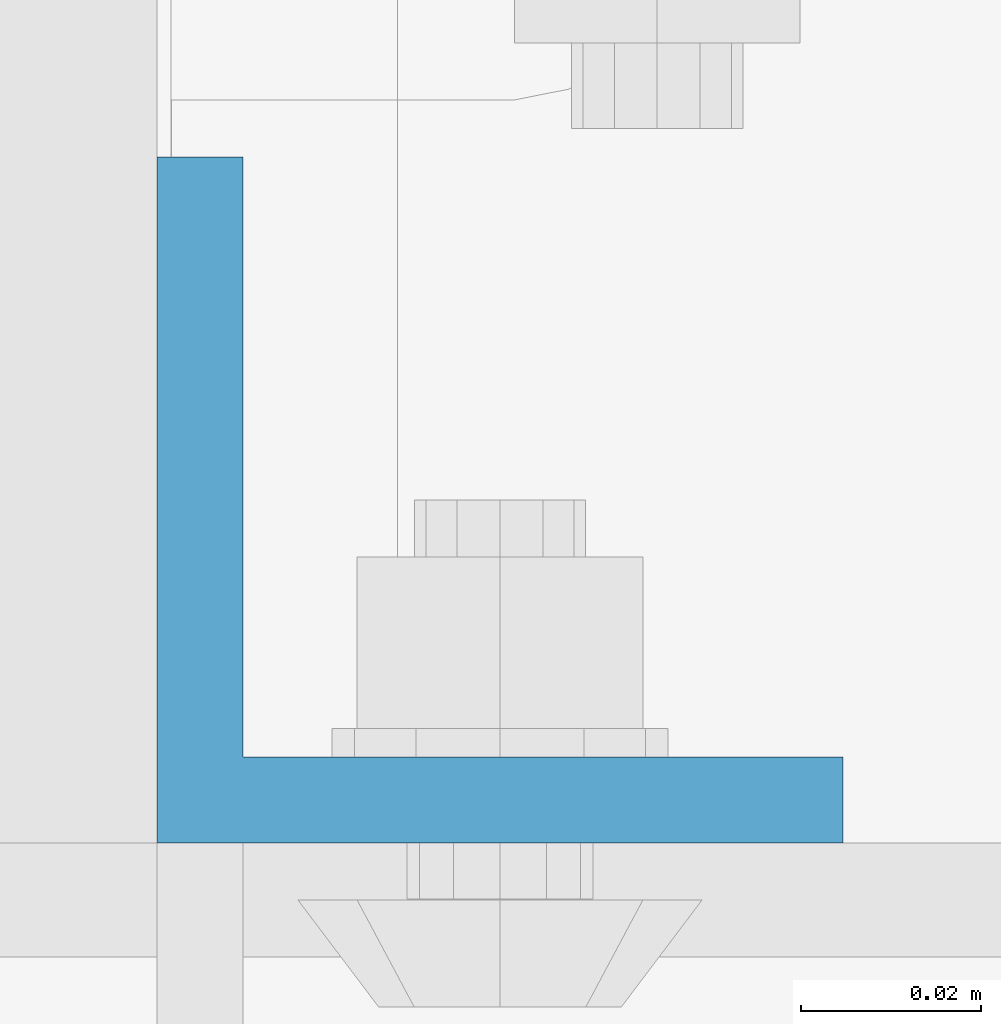
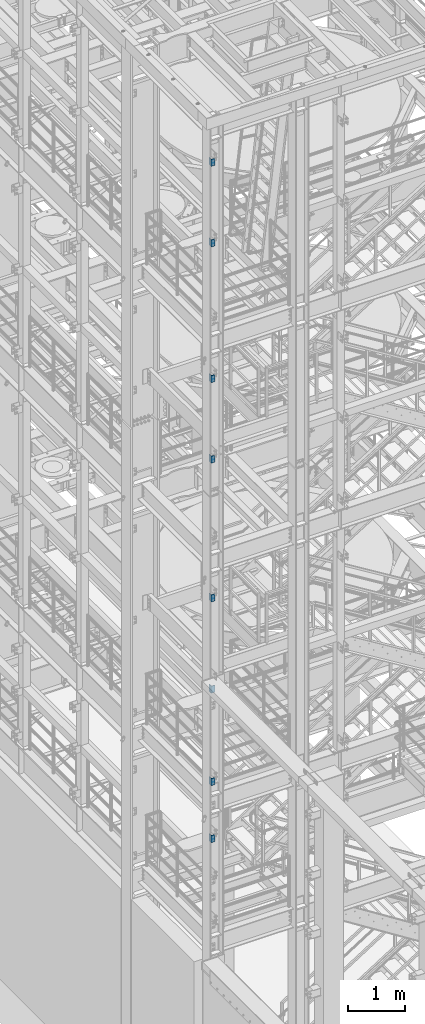
# One storey, part 800 of 1876: 8 columns, 2 elements without a shape of their own.
"""IFC2X3 building model written with IfcOpenShell, lengths in millimetres."""

from ifc_helpers import new_model, si_unit, frame, origin_with_axes, place, context, subcontext, project, spatial, faceted_brep, material, type_object, element, aggregate, save


model = new_model("IFC2X3")

# Units and contexts
model_context = context("Model", 3, precision=1e-05, world=origin_with_axes())
body_context = subcontext(model_context, "Body", "Model", "MODEL_VIEW")
ifc_project = project(units=[si_unit("LENGTHUNIT", "METRE", prefix="MILLI"), si_unit("AREAUNIT", "SQUARE_METRE"), si_unit("VOLUMEUNIT", "CUBIC_METRE"), si_unit("MASSUNIT", "GRAM", prefix="KILO"), si_unit("TIMEUNIT", "SECOND"), si_unit("PLANEANGLEUNIT", "RADIAN"), si_unit("SOLIDANGLEUNIT", "STERADIAN"), si_unit("THERMODYNAMICTEMPERATUREUNIT", "DEGREE_CELSIUS"), si_unit("LUMINOUSINTENSITYUNIT", "LUMEN")], contexts=[model_context])

# Site, building, storey
site_placement = place(None, origin_with_axes())
site = spatial("IfcSite", under=ifc_project, at=site_placement, CompositionType="ELEMENT")
building_placement = place(site_placement, origin_with_axes())
building = spatial("IfcBuilding", under=site, at=building_placement, Name="Undefined", CompositionType="ELEMENT")
storey_placement = place(building_placement, origin_with_axes())
storey = spatial("IfcBuildingStorey", under=building, at=storey_placement, Name="Undefined", CompositionType="ELEMENT", Elevation=0.0)

# Assembly, columns
assembly_1_placement = place(storey_placement, origin_with_axes())
assembly_1 = element("IfcElementAssembly", 1, at=assembly_1_placement, inside=storey, Name="COLUMN", AssemblyPlace="NOTDEFINED", PredefinedType="RIGID_FRAME")
ifc_material = material(Name="STEEL/A36")
column_type = type_object("IfcColumnType", Name="L3X3X3/8", PredefinedType="NOTDEFINED")
column_1_placement = place(assembly_1_placement, frame((-74.6125, -7204.075, 21602.7), z_axis=(1.0, 0.0, 0.0), x_axis=(0.0, 0.0, 1.0)))
column_1 = element("IfcColumn", 2, at=column_1_placement, type_object=column_type, material=ifc_material, Name="ANGLE", ObjectType="L3X3X3/8", context=body_context, shape_type="Brep", body=[
    faceted_brep([(0.0, 38.1000000000004, -38.1), (0.0, 38.1000000000004, 38.1), (152.4, 38.1000000000004, 38.1), (152.4, 38.1000000000004, -38.1), (0.0, 28.5749999999998, 38.1), (152.4, 28.5749999999998, 38.1), (0.0, 28.5749999999998, -28.575), (152.4, 28.5749999999998, -28.575), (0.0, -38.1000000000004, -28.575), (152.4, -38.1000000000004, -28.575), (0.0, -38.1000000000004, -38.1), (152.4, -38.1000000000004, -38.1)], [[[0, 1, 2, 3]], [[1, 4, 5, 2]], [[4, 6, 7, 5]], [[6, 8, 9, 7]], [[8, 10, 11, 9]], [[10, 0, 3, 11]], [[5, 7, 9, 11, 3, 2]], [[10, 8, 6, 4, 1, 0]]]),
])
column_2_placement = place(assembly_1_placement, frame((-74.6125, -7204.075, 19881.85), z_axis=(1.0, 0.0, 0.0), x_axis=(0.0, 0.0, 1.0)))
column_2 = element("IfcColumn", 3, at=column_2_placement, type_object=column_type, material=ifc_material, Name="ANGLE", ObjectType="L3X3X3/8", context=body_context, shape_type="Brep", body=[
    faceted_brep([(0.0, 38.1000000000004, -38.1), (0.0, 38.1000000000004, 38.1), (152.4, 38.1000000000004, 38.1), (152.4, 38.1000000000004, -38.1), (0.0, 28.5749999999998, 38.1), (152.4, 28.5749999999998, 38.1), (0.0, 28.5749999999998, -28.575), (152.4, 28.5749999999998, -28.575), (0.0, -38.1000000000004, -28.575), (152.4, -38.1000000000004, -28.575), (0.0, -38.1000000000004, -38.1), (152.4, -38.1000000000004, -38.1)], [[[0, 1, 2, 3]], [[1, 4, 5, 2]], [[4, 6, 7, 5]], [[6, 8, 9, 7]], [[8, 10, 11, 9]], [[10, 0, 3, 11]], [[5, 7, 9, 11, 3, 2]], [[10, 8, 6, 4, 1, 0]]]),
])
column_3_placement = place(assembly_1_placement, frame((-74.6125, -7204.075, 16979.9), z_axis=(1.0, 0.0, 0.0), x_axis=(0.0, 0.0, 1.0)))
column_3 = element("IfcColumn", 4, at=column_3_placement, type_object=column_type, material=ifc_material, Name="ANGLE", ObjectType="L3X3X3/8", context=body_context, shape_type="Brep", body=[
    faceted_brep([(0.0, 38.1000000000004, -38.1), (0.0, 38.1000000000004, 38.1), (152.4, 38.1000000000004, 38.1), (152.4, 38.1000000000004, -38.1), (0.0, 28.5749999999998, 38.1), (152.4, 28.5749999999998, 38.1), (0.0, 28.5749999999998, -28.575), (152.4, 28.5749999999998, -28.575), (0.0, -38.1000000000004, -28.575), (152.4, -38.1000000000004, -28.575), (0.0, -38.1000000000004, -38.1), (152.4, -38.1000000000004, -38.1)], [[[0, 1, 2, 3]], [[1, 4, 5, 2]], [[4, 6, 7, 5]], [[6, 8, 9, 7]], [[8, 10, 11, 9]], [[10, 0, 3, 11]], [[5, 7, 9, 11, 3, 2]], [[10, 8, 6, 4, 1, 0]]]),
])
column_4_placement = place(assembly_1_placement, frame((-74.6125, -7204.075, 15259.05), z_axis=(1.0, 0.0, 0.0), x_axis=(0.0, 0.0, 1.0)))
column_4 = element("IfcColumn", 5, at=column_4_placement, type_object=column_type, material=ifc_material, Name="ANGLE", ObjectType="L3X3X3/8", context=body_context, shape_type="Brep", body=[
    faceted_brep([(0.0, 38.1000000000004, -38.1), (0.0, 38.1000000000004, 38.1), (152.4, 38.1000000000004, 38.1), (152.4, 38.1000000000004, -38.1), (0.0, 28.5749999999998, 38.1), (152.4, 28.5749999999998, 38.1), (0.0, 28.5749999999998, -28.575), (152.4, 28.5749999999998, -28.575), (0.0, -38.1000000000004, -28.575), (152.4, -38.1000000000004, -28.575), (0.0, -38.1000000000004, -38.1), (152.4, -38.1000000000004, -38.1)], [[[0, 1, 2, 3]], [[1, 4, 5, 2]], [[4, 6, 7, 5]], [[6, 8, 9, 7]], [[8, 10, 11, 9]], [[10, 0, 3, 11]], [[5, 7, 9, 11, 3, 2]], [[10, 8, 6, 4, 1, 0]]]),
])
aggregate(assembly_1, [column_1, column_2, column_3, column_4])

assembly_2_placement = place(storey_placement, origin_with_axes())
assembly_2 = element("IfcElementAssembly", 6, at=assembly_2_placement, inside=storey, Name="COLUMN", AssemblyPlace="NOTDEFINED", PredefinedType="RIGID_FRAME")
column_5_placement = place(assembly_2_placement, frame((-74.6125, -7204.075, 12293.6), z_axis=(1.0, 0.0, 0.0), x_axis=(0.0, 0.0, 1.0)))
column_5 = element("IfcColumn", 7, at=column_5_placement, type_object=column_type, material=ifc_material, Name="ANGLE", ObjectType="L3X3X3/8", context=body_context, shape_type="Brep", body=[
    faceted_brep([(0.0, 38.1000000000004, -38.1), (0.0, 38.1000000000004, 38.1), (152.4, 38.1000000000004, 38.1), (152.4, 38.1000000000004, -38.1), (0.0, 28.5749999999998, 38.1), (152.4, 28.5749999999998, 38.1), (0.0, 28.5749999999998, -28.575), (152.4, 28.5749999999998, -28.575), (0.0, -38.1000000000004, -28.575), (152.4, -38.1000000000004, -28.575), (0.0, -38.1000000000004, -38.1), (152.4, -38.1000000000004, -38.1)], [[[0, 1, 2, 3]], [[1, 4, 5, 2]], [[4, 6, 7, 5]], [[6, 8, 9, 7]], [[8, 10, 11, 9]], [[10, 0, 3, 11]], [[5, 7, 9, 11, 3, 2]], [[10, 8, 6, 4, 1, 0]]]),
])
column_6_placement = place(assembly_2_placement, frame((-74.6125, -7204.075, 10344.15), z_axis=(1.0, 0.0, 0.0), x_axis=(0.0, 0.0, 1.0)))
column_6 = element("IfcColumn", 8, at=column_6_placement, type_object=column_type, material=ifc_material, Name="ANGLE", ObjectType="L3X3X3/8", context=body_context, shape_type="Brep", body=[
    faceted_brep([(0.0, 38.1000000000004, -38.1), (0.0, 38.1000000000004, 38.1), (152.4, 38.1000000000004, 38.1), (152.4, 38.1000000000004, -38.1), (0.0, 28.5749999999998, 38.1), (152.4, 28.5749999999998, 38.1), (0.0, 28.5749999999998, -28.575), (152.4, 28.5749999999998, -28.575), (0.0, -38.1000000000004, -28.575), (152.4, -38.1000000000004, -28.575), (0.0, -38.1000000000004, -38.1), (152.4, -38.1000000000004, -38.1)], [[[0, 1, 2, 3]], [[1, 4, 5, 2]], [[4, 6, 7, 5]], [[6, 8, 9, 7]], [[8, 10, 11, 9]], [[10, 0, 3, 11]], [[5, 7, 9, 11, 3, 2]], [[10, 8, 6, 4, 1, 0]]]),
])
column_7_placement = place(assembly_2_placement, frame((-74.6125, -7204.075, 8369.3), z_axis=(1.0, 0.0, 0.0), x_axis=(0.0, 0.0, 1.0)))
column_7 = element("IfcColumn", 9, at=column_7_placement, type_object=column_type, material=ifc_material, Name="ANGLE", ObjectType="L3X3X3/8", context=body_context, shape_type="Brep", body=[
    faceted_brep([(0.0, 38.1000000000004, -38.1), (0.0, 38.1000000000004, 38.1), (152.4, 38.1000000000004, 38.1), (152.4, 38.1000000000004, -38.1), (0.0, 28.5749999999998, 38.1), (152.4, 28.5749999999998, 38.1), (0.0, 28.5749999999998, -28.575), (152.4, 28.5749999999998, -28.575), (0.0, -38.1000000000004, -28.575), (152.4, -38.1000000000004, -28.575), (0.0, -38.1000000000004, -38.1), (152.4, -38.1000000000004, -38.1)], [[[0, 1, 2, 3]], [[1, 4, 5, 2]], [[4, 6, 7, 5]], [[6, 8, 9, 7]], [[8, 10, 11, 9]], [[10, 0, 3, 11]], [[5, 7, 9, 11, 3, 2]], [[10, 8, 6, 4, 1, 0]]]),
])
column_8_placement = place(assembly_2_placement, frame((-74.6125, -7204.075, 7150.1), z_axis=(1.0, 0.0, 0.0), x_axis=(0.0, 0.0, 1.0)))
column_8 = element("IfcColumn", 10, at=column_8_placement, type_object=column_type, material=ifc_material, Name="ANGLE", ObjectType="L3X3X3/8", context=body_context, shape_type="Brep", body=[
    faceted_brep([(0.0, 38.1000000000004, -38.1), (0.0, 38.1000000000004, 38.1), (152.4, 38.1000000000004, 38.1), (152.4, 38.1000000000004, -38.1), (0.0, 28.5749999999998, 38.1), (152.4, 28.5749999999998, 38.1), (0.0, 28.5749999999998, -28.575), (152.4, 28.5749999999998, -28.575), (0.0, -38.1000000000004, -28.575), (152.4, -38.1000000000004, -28.575), (0.0, -38.1000000000004, -38.1), (152.4, -38.1000000000004, -38.1)], [[[0, 1, 2, 3]], [[1, 4, 5, 2]], [[4, 6, 7, 5]], [[6, 8, 9, 7]], [[8, 10, 11, 9]], [[10, 0, 3, 11]], [[5, 7, 9, 11, 3, 2]], [[10, 8, 6, 4, 1, 0]]]),
])
aggregate(assembly_2, [column_5, column_6, column_7, column_8])

save(model, "model.ifc")
